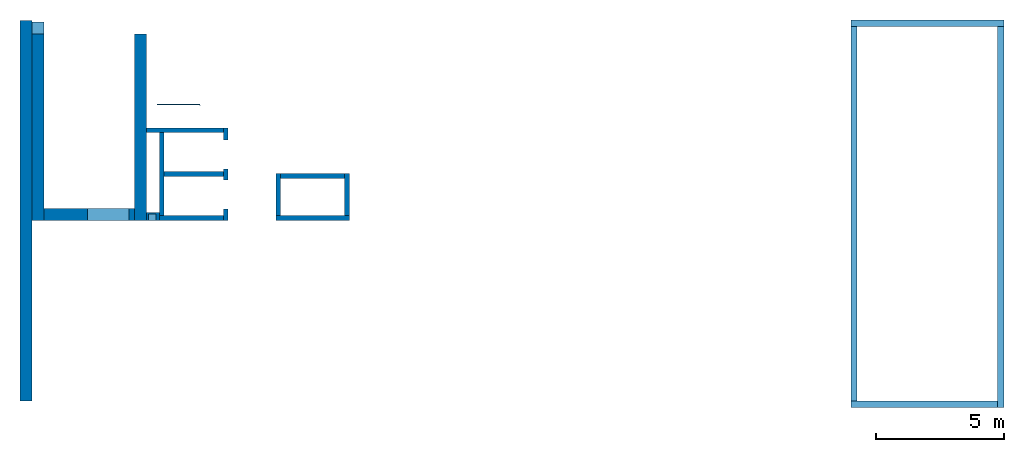
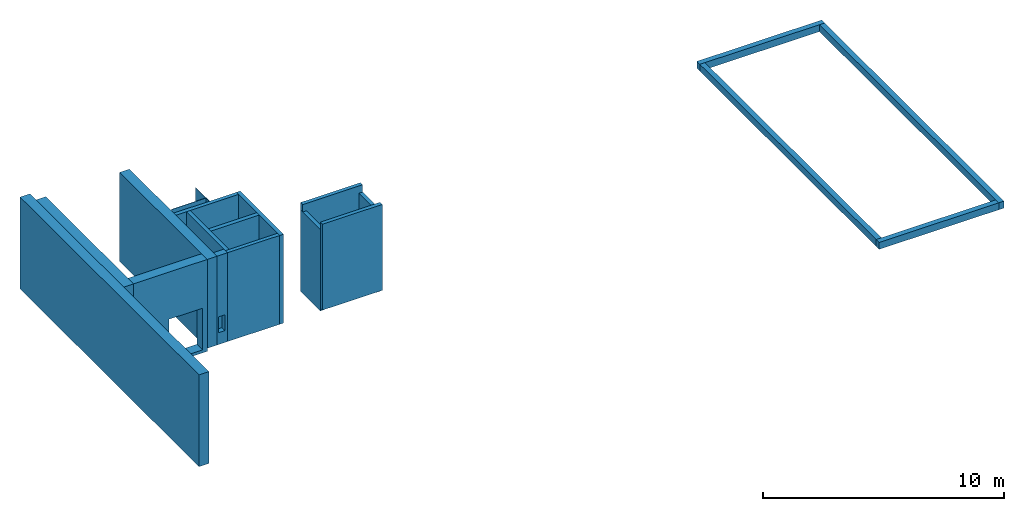
# One storey: 20 walls, 6 openings.
"""IFC4 building model written with IfcOpenShell, lengths in metres."""

from ifc_helpers import new_model, entity, si_unit, converted_unit, derived_unit, direction, frame, origin_with_axes, place, context, subcontext, project, spatial, polygons, material, type_object, element, save


model = new_model("IFC4")

# Units and contexts
model_context = context("Model", 3, precision=1e-05, world=origin_with_axes(), true_north=direction((0.0, 1.0)))
body_context = subcontext(model_context, "Body", "Model", "MODEL_VIEW")
ifc_project = project(units=[si_unit("LENGTHUNIT", "METRE"), si_unit("AREAUNIT", "SQUARE_METRE"), si_unit("VOLUMEUNIT", "CUBIC_METRE"), converted_unit("PLANEANGLEUNIT", "DEGREE", entity("IfcPlaneAngleMeasure", 0.0174532925199433), si_unit("PLANEANGLEUNIT", "RADIAN"), dimensions=[0, 0, 0, 0, 0, 0, 0]), converted_unit("TIMEUNIT", "Year", entity("IfcTimeMeasure", 31557600.0), si_unit("TIMEUNIT", "SECOND"), dimensions=[0, 0, 1, 0, 0, 0, 0]), si_unit("MASSUNIT", "GRAM", prefix="KILO"), si_unit("THERMODYNAMICTEMPERATUREUNIT", "DEGREE_CELSIUS"), si_unit("LUMINOUSINTENSITYUNIT", "LUMEN"), si_unit("ENERGYUNIT", "JOULE", prefix="MEGA"), derived_unit("THERMALCONDUCTANCEUNIT", [(si_unit("POWERUNIT", "WATT"), 1), (si_unit("LENGTHUNIT", "METRE"), -1), (si_unit("THERMODYNAMICTEMPERATUREUNIT", "KELVIN"), -1)]), derived_unit("SPECIFICHEATCAPACITYUNIT", [(si_unit("ENERGYUNIT", "JOULE"), 1), (si_unit("MASSUNIT", "GRAM", prefix="KILO"), -1), (si_unit("THERMODYNAMICTEMPERATUREUNIT", "KELVIN"), -1)]), derived_unit("MASSDENSITYUNIT", [(si_unit("MASSUNIT", "GRAM", prefix="KILO"), 1), (si_unit("VOLUMEUNIT", "CUBIC_METRE"), -1)])], contexts=[model_context])

# Site, building, storey
site_placement = place(None, origin_with_axes())
site = spatial("IfcSite", under=ifc_project, at=site_placement, CompositionType="ELEMENT")
building_placement = place(None, origin_with_axes())
building = spatial("IfcBuilding", under=site, at=building_placement, CompositionType="ELEMENT")
storey_placement = place(None, origin_with_axes())
storey = spatial("IfcBuildingStorey", under=building, at=storey_placement, Name="EG", CompositionType="ELEMENT", Elevation=0.0)

# Walls
ifc_material_1 = material(Name="Stahlbeton")
wall_type_1 = type_object("IfcWallType", Name="Stahlbeton 180", PredefinedType="NOTDEFINED")
wall_1_placement = place(None, frame((28.958, 7.05499994546755, 0.0), z_axis=(0.0, 0.0, 1.0), x_axis=(1.0, 0.0, 0.0)))
element("IfcWall", 1, at=wall_1_placement, inside=storey, type_object=wall_type_1, material=ifc_material_1, Name="Wand-001", PredefinedType="NOTDEFINED", context=body_context, shape_type="Tessellation", body=[
    polygons([(2.5, 0.180000000000001, 0.0), (2.5, 0.0, 0.0), (0.0, 0.0, 0.0), (0.0, 0.18, 0.0), (2.5, 0.180000000000001, 4.5), (2.5, 0.0, 4.5), (0.0, 0.0, 4.5), (0.0, 0.180000000000001, 4.5)], [[[1, 2, 3, 4]], [[2, 1, 5, 6]], [[2, 6, 7, 3]], [[8, 4, 3, 7]], [[5, 1, 4, 8]], [[6, 5, 8, 7]]], closed=True),
])
wall_2_placement = place(None, frame((29.138, 7.05499994546755, 0.0), z_axis=(0.0, 0.0, 1.0), x_axis=(0.0, 1.0, 0.0)))
element("IfcWall", 2, at=wall_2_placement, inside=storey, type_object=wall_type_1, material=ifc_material_1, Name="Wand-003", PredefinedType="NOTDEFINED", context=body_context, shape_type="Tessellation", body=[
    polygons([(3.42, 0.18, 4.5), (0.180000000000001, 0.18, 4.5), (0.180000000000001, 0.0, 4.5), (3.42, 0.0, 4.5), (3.42, 0.18, 0.0), (0.18, 0.18, 0.0), (0.18, 0.0, 0.0), (3.42, 0.0, 0.0)], [[[1, 2, 3, 4]], [[5, 6, 2, 1]], [[6, 7, 3, 2]], [[4, 3, 7, 8]], [[5, 1, 4, 8]], [[8, 7, 6, 5]]], closed=True),
])
wall_3_placement = place(None, frame((36.373, 7.05499994546756, -0.15), z_axis=(0.0, 0.0, 1.0), x_axis=(0.0, 1.0, 0.0)))
element("IfcWall", 3, at=wall_3_placement, inside=storey, type_object=wall_type_1, material=ifc_material_1, Name="Wand-001", PredefinedType="NOTDEFINED", context=body_context, shape_type="Tessellation", body=[
    polygons([(0.18, 0.18, 4.13), (0.179999999999998, 0.18, 0.0), (0.179999999999998, 0.0, 0.0), (0.18, 0.0, 4.13), (1.818, 0.18, 0.0), (1.818, 0.18, 4.13), (1.818, 0.0, 0.0), (1.818, 0.0, 4.13)], [[[1, 2, 3, 4]], [[5, 2, 1, 6]], [[7, 3, 2, 5]], [[4, 3, 7, 8]], [[6, 1, 4, 8]], [[6, 8, 7, 5]]], closed=True),
])
wall_4_placement = place(None, frame((31.638, 10.6549999454676, 0.0), z_axis=(0.0, 0.0, 1.0), x_axis=(-1.0, 0.0, 0.0)))
element("IfcWall", 4, at=wall_4_placement, inside=storey, type_object=wall_type_1, material=ifc_material_1, Name="Wand-003", PredefinedType="NOTDEFINED", context=body_context, shape_type="Tessellation", body=[
    polygons([(3.18, 0.18, 0.0), (3.18, 0.0, 0.0), (0.18, 0.0, 0.0), (0.18, 0.18, 0.0), (3.18, 0.18, 4.5), (3.18, 0.0, 4.5), (0.18, 0.0, 4.5), (0.18, 0.18, 4.5)], [[[1, 2, 3, 4]], [[2, 1, 5, 6]], [[2, 6, 7, 3]], [[8, 4, 3, 7]], [[5, 1, 4, 8]], [[6, 5, 8, 7]]], closed=True),
])

# Wall, openings
wall_5_placement = place(None, frame((31.638, 7.05499994546755, 0.0), z_axis=(0.0, 0.0, 1.0), x_axis=(0.0, 1.0, 0.0)))
wall_5 = element("IfcWall", 5, at=wall_5_placement, inside=storey, type_object=wall_type_1, material=ifc_material_1, Name="Wand-002", PredefinedType="NOTDEFINED", context=body_context, shape_type="Tessellation", body=[
    polygons([(2.0, 0.0, 0.0), (2.0, 0.0, 2.25), (3.13, 0.0, 2.25), (3.13, 0.0, 0.0), (3.6, 0.0, 0.0), (3.6, 0.0, 4.5), (0.0, 0.0, 4.5), (0.0, 0.0, 0.0), (0.450000000000002, 0.0, 0.0), (0.450000000000002, 0.0, 2.25), (1.58, 0.0, 2.25), (1.58, 0.0, 0.0), (2.0, 0.179999999999996, 0.0), (2.0, 0.179999999999996, 2.25), (3.13, 0.179999999999996, 2.25), (3.13, 0.179999999999996, 0.0), (3.6, 0.179999999999996, 0.0), (3.6, 0.179999999999996, 4.5), (0.0, 0.18, 4.5), (0.0, 0.18, 0.0), (0.450000000000002, 0.18, 0.0), (0.450000000000002, 0.18, 2.25), (1.58, 0.18, 2.25), (1.58, 0.18, 0.0)], [[[1, 2, 3, 4, 5, 6, 7, 8, 9, 10, 11, 12]], [[2, 1, 13, 14]], [[3, 2, 14, 15]], [[4, 3, 15, 16]], [[4, 16, 17, 5]], [[5, 17, 18, 6]], [[7, 6, 18, 19]], [[7, 19, 20, 8]], [[9, 8, 20, 21]], [[9, 21, 22, 10]], [[10, 22, 23, 11]], [[11, 23, 24, 12]], [[13, 1, 12, 24]], [[14, 13, 24, 23, 22, 21, 20, 19, 18, 17, 16, 15]]], closed=True),
])
opening_1_placement = place(wall_5_placement, frame((2.565, 0.0, 0.0), z_axis=(0.0, 0.0, 1.0), x_axis=(1.0, 0.0, 0.0)))
element("IfcOpeningElement", 6, at=opening_1_placement, cuts=wall_5, context=body_context, identifier="Reference", shape_type="Tessellation", body=[
    polygons([(-0.565, -0.00100000000000478, 2.25), (-0.565, -0.00100000000000478, 0.0), (0.565, -0.00100000000000478, 0.0), (0.565, -0.00100000000000478, 2.25), (-0.564999999999998, 0.181000000000001, 2.25), (-0.564999999999998, 0.181000000000001, 0.0), (0.565000000000001, 0.181000000000001, 0.0), (0.565000000000001, 0.181000000000001, 2.25)], [[[1, 2, 3, 4]], [[5, 6, 2, 1]], [[6, 7, 3, 2]], [[7, 8, 4, 3]], [[8, 5, 1, 4]], [[7, 6, 5, 8]]], closed=True),
])
opening_2_placement = place(wall_5_placement, frame((1.015, 0.0, 0.0), z_axis=(0.0, 0.0, 1.0), x_axis=(1.0, 0.0, 0.0)))
element("IfcOpeningElement", 7, at=opening_2_placement, cuts=wall_5, context=body_context, identifier="Reference", shape_type="Tessellation", body=[
    polygons([(-0.565, -0.00100000000000122, 2.25), (-0.565, -0.00100000000000122, 0.0), (0.565, -0.00100000000000122, 0.0), (0.565, -0.00100000000000122, 2.25), (-0.565, 0.181000000000004, 2.25), (-0.565, 0.181000000000004, 0.0), (0.565000000000001, 0.181000000000004, 0.0), (0.565000000000001, 0.181000000000004, 2.25)], [[[1, 2, 3, 4]], [[5, 6, 2, 1]], [[6, 7, 3, 2]], [[7, 8, 4, 3]], [[8, 5, 1, 4]], [[7, 6, 5, 8]]], closed=True),
])

# Walls
wall_6_placement = place(None, frame((36.373, 8.87299994546756, -0.15), z_axis=(0.0, 0.0, 1.0), x_axis=(-1.0, 0.0, 0.0)))
element("IfcWall", 8, at=wall_6_placement, inside=storey, type_object=wall_type_1, material=ifc_material_1, Name="Wand-001", PredefinedType="NOTDEFINED", context=body_context, shape_type="Tessellation", body=[
    polygons([(0.0, 0.18, 4.5), (0.0, 0.18, 4.13), (0.0, 0.0, 4.13), (0.0, 0.0, 4.5), (0.18, 0.18, 0.0), (0.18, 0.18, 4.13), (2.868, 0.18, 4.5), (2.868, 0.18, 4.13), (2.688, 0.18, 4.13), (2.688, 0.18, 0.0), (0.18, 0.0, 4.13), (0.18, 0.0, 0.0), (2.688, 0.0, 0.0), (2.688, 0.0, 4.13), (2.868, 0.0, 4.13), (2.868, 0.0, 4.5)], [[[1, 2, 3, 4]], [[5, 6, 2, 1, 7, 8, 9, 10]], [[6, 11, 3, 2]], [[3, 11, 12, 13, 14, 15, 16, 4]], [[1, 4, 16, 7]], [[5, 12, 11, 6]], [[16, 15, 8, 7]], [[8, 15, 14, 9]], [[9, 14, 13, 10]], [[13, 12, 5, 10]]], closed=True),
])
wall_7_placement = place(None, frame((33.505, 7.05499994546756, -0.15), z_axis=(0.0, 0.0, 1.0), x_axis=(0.0, 1.0, 0.0)))
element("IfcWall", 9, at=wall_7_placement, inside=storey, type_object=wall_type_1, material=ifc_material_1, Name="Wand-001", PredefinedType="NOTDEFINED", context=body_context, shape_type="Tessellation", body=[
    polygons([(0.18, 0.0, 4.13), (0.179999999999998, 0.0, 0.0), (0.179999999999998, -0.18, 0.0), (0.18, -0.18, 4.13), (1.818, 0.0, 0.0), (1.818, 0.0, 4.13), (1.818, -0.18, 0.0), (1.818, -0.18, 4.13)], [[[1, 2, 3, 4]], [[5, 2, 1, 6]], [[7, 3, 2, 5]], [[4, 3, 7, 8]], [[6, 1, 4, 8]], [[6, 8, 7, 5]]], closed=True),
])

# Space
space_placement = place(None, frame((28.883, 12.4404999136732, 0.0), z_axis=(0.0, 0.0, 1.0), x_axis=(0.0, -1.0, 0.0)))
space = spatial("IfcSpace", under=storey, at=space_placement, CompositionType="ELEMENT", PredefinedType="NOTDEFINED")

# Wall
ifc_material_2 = material(Name="Kunststoff")
wall_type_2 = type_object("IfcWallType", Name="Kunststoff 20", PredefinedType="NOTDEFINED")
wall_8_placement = place(None, frame((30.553, 11.5727499295704, -0.15), z_axis=(0.0, 0.0, 1.0), x_axis=(-1.0, 0.0, 0.0)))
element("IfcWall", 10, at=wall_8_placement, inside=space, type_object=wall_type_2, material=ifc_material_2, Name="Wand-003", PredefinedType="NOTDEFINED", context=body_context, shape_type="Tessellation", body=[
    polygons([(0.0199999999999996, -0.00999999999999979, 2.87), (0.0199999999999996, 0.00999999999999979, 2.87), (0.0199999999999996, 0.00999999999999979, 0.15), (0.0199999999999996, -0.00999999999999979, 0.15), (1.67, -0.00999999999999979, 2.87), (1.67, 0.00999999999999979, 2.87), (1.67, 0.00999999999999979, 0.15), (1.67, -0.00999999999999979, 0.15)], [[[1, 2, 3, 4]], [[5, 6, 2, 1]], [[2, 6, 7, 3]], [[3, 7, 8, 4]], [[5, 1, 4, 8]], [[6, 5, 8, 7]]], closed=True),
    polygons([(0.0199999999999996, 0.00999999999999979, 4.13), (0.0199999999999996, 0.00999999999999979, 2.9), (0.0199999999999996, -0.00999999999999979, 2.9), (0.0199999999999996, -0.00999999999999979, 4.13), (1.67, 0.00999999999999979, 4.13), (1.67, 0.00999999999999979, 2.9), (1.67, -0.00999999999999979, 2.9), (1.67, -0.00999999999999979, 4.13)], [[[1, 2, 3, 4]], [[5, 6, 2, 1]], [[6, 7, 3, 2]], [[4, 3, 7, 8]], [[4, 8, 5, 1]], [[8, 7, 6, 5]]], closed=True),
])

# Wall, openings
wall_9_placement = place(None, frame((30.553, 10.6549999454676, -0.15), z_axis=(0.0, 0.0, 1.0), x_axis=(0.0, 1.0, 0.0)))
wall_9 = element("IfcWall", 11, at=wall_9_placement, inside=space, type_object=wall_type_2, material=ifc_material_2, Name="Wand-003", PredefinedType="NOTDEFINED", context=body_context, shape_type="Tessellation", body=[
    polygons([(0.895499968205613, 0.0, 0.15), (0.895499968205613, 0.0, 2.245), (1.78549996820561, 0.0, 2.245), (1.78549996820561, 0.0, 2.87), (0.0, 0.0, 2.87), (0.0, 0.0, 2.245), (0.890000000000001, 0.0, 2.245), (0.890000000000001, 0.0, 0.15), (0.895499968205613, 0.0199999999999996, 0.15), (0.895499968205613, 0.0199999999999996, 2.245), (1.78549996820561, 0.0199999999999996, 2.245), (1.78549996820561, 0.0199999999999996, 2.87), (0.0, 0.0199999999999996, 2.87), (0.0, 0.0199999999999996, 2.245), (0.890000000000001, 0.0199999999999996, 2.245), (0.890000000000001, 0.0199999999999996, 0.15)], [[[1, 2, 3, 4, 5, 6, 7, 8]], [[2, 1, 9, 10]], [[11, 3, 2, 10]], [[3, 11, 12, 4]], [[4, 12, 13, 5]], [[6, 5, 13, 14]], [[6, 14, 15, 7]], [[7, 15, 16, 8]], [[9, 1, 8, 16]], [[10, 9, 16, 15, 14, 13, 12, 11]]], closed=True),
    polygons([(0.0, 0.0, 4.13), (0.0, 0.0, 2.9), (1.78549996820561, 0.0, 2.9), (1.78549996820561, 0.0, 4.13), (0.0, 0.0199999999999996, 4.13), (0.0, 0.0199999999999996, 2.9), (1.78549996820561, 0.0199999999999996, 2.9), (1.78549996820561, 0.0199999999999996, 4.13)], [[[1, 2, 3, 4]], [[5, 6, 2, 1]], [[6, 7, 3, 2]], [[4, 3, 7, 8]], [[4, 8, 5, 1]], [[8, 7, 6, 5]]], closed=True),
])
opening_3_placement = place(wall_9_placement, frame((1.34049996820561, 0.0, 0.2), z_axis=(0.0, 0.0, 1.0), x_axis=(1.0, 0.0, 0.0)))
element("IfcOpeningElement", 12, at=opening_3_placement, cuts=wall_9, context=body_context, identifier="Reference", shape_type="Tessellation", body=[
    polygons([(0.445, 0.0210000000000008, 2.045), (0.445, 0.0210000000000008, -0.05), (-0.445, 0.0210000000000008, -0.05), (-0.445, 0.0210000000000008, 2.045), (0.445, -0.00100000000000122, 2.045), (0.445, -0.00100000000000122, -0.05), (-0.445, -0.00100000000000122, -0.05), (-0.445, -0.00100000000000122, 2.045)], [[[1, 2, 3, 4]], [[5, 6, 2, 1]], [[6, 7, 3, 2]], [[7, 8, 4, 3]], [[8, 5, 1, 4]], [[7, 6, 5, 8]]], closed=True),
])
opening_4_placement = place(wall_9_placement, frame((0.445, 0.0, 0.2), z_axis=(0.0, 0.0, 1.0), x_axis=(1.0, 0.0, 0.0)))
element("IfcOpeningElement", 13, at=opening_4_placement, cuts=wall_9, context=body_context, identifier="Reference", shape_type="Tessellation", body=[
    polygons([(0.445, 0.0210000000000008, 2.045), (0.445, 0.0210000000000008, -0.05), (-0.445, 0.0210000000000008, -0.05), (-0.445, 0.0210000000000008, 2.045), (0.445, -0.00100000000000122, 2.045), (0.445, -0.00100000000000122, -0.05), (-0.445, -0.00100000000000122, -0.05), (-0.445, -0.00100000000000122, 2.045)], [[[1, 2, 3, 4]], [[5, 6, 2, 1]], [[6, 7, 3, 2]], [[7, 8, 4, 3]], [[8, 5, 1, 4]], [[7, 6, 5, 8]]], closed=True),
])

# Wall, opening
wall_type_3 = type_object("IfcWallType", Name="Stahlbeton 470", PredefinedType="NOTDEFINED")
wall_10_placement = place(None, frame((24.458, 7.52499994546755, -0.15), z_axis=(0.0, 0.0, 1.0), x_axis=(1.0, 0.0, 0.0)))
wall_10 = element("IfcWall", 14, at=wall_10_placement, inside=storey, type_object=wall_type_3, material=ifc_material_1, Name="Wand-001", PredefinedType="NOTDEFINED", context=body_context, shape_type="Tessellation", body=[
    polygons([(3.53, -0.470000000000001, 0.0), (3.53, -0.47, 4.65), (0.0, -0.47, 4.65), (0.0, -0.47, 0.0), (1.69000000000001, -0.47, 0.15), (1.69000000000001, -0.47, 2.26), (3.31, -0.47, 2.26), (3.31, -0.47, 0.15), (3.53, 0.0, 0.0), (3.53, 0.0, 4.65), (0.0, 0.0, 4.65), (0.0, 0.0, 0.0), (1.69000000000001, 0.0, 0.15), (1.69000000000001, 0.0, 2.26), (3.31, 0.0, 2.26), (3.31, 0.0, 0.15)], [[[1, 2, 3, 4], [5, 6, 7, 8]], [[1, 9, 10, 2]], [[2, 10, 11, 3]], [[11, 12, 4, 3]], [[9, 1, 4, 12]], [[13, 14, 6, 5]], [[14, 15, 7, 6]], [[15, 16, 8, 7]], [[16, 13, 5, 8]], [[9, 12, 11, 10], [13, 16, 15, 14]]], closed=True),
])
opening_5_placement = place(wall_10_placement, frame((2.5, 0.0, 0.15), z_axis=(0.0, 0.0, 1.0), x_axis=(1.0, 0.0, 0.0)))
element("IfcOpeningElement", 15, at=opening_5_placement, cuts=wall_10, context=body_context, identifier="Reference", shape_type="Tessellation", body=[
    polygons([(0.809999999999999, 0.00100000000000033, 2.11), (0.809999999999999, 0.00100000000000033, 0.0), (-0.809999999999999, 0.00100000000000033, 0.0), (-0.809999999999999, 0.00100000000000122, 2.11), (0.809999999999999, -0.471000000000001, 2.11), (0.809999999999999, -0.471000000000001, 0.0), (-0.809999999999999, -0.471000000000001, 0.0), (-0.809999999999999, -0.471, 2.11)], [[[1, 2, 3, 4]], [[5, 6, 2, 1]], [[6, 7, 3, 2]], [[7, 8, 4, 3]], [[8, 5, 1, 4]], [[7, 6, 5, 8]]], closed=True),
])

# Walls
wall_11_placement = place(None, frame((27.988, 14.3259998818788, 0.0), z_axis=(0.0, 0.0, 1.0), x_axis=(0.0, -1.0, 0.0)))
element("IfcWall", 16, at=wall_11_placement, inside=storey, type_object=wall_type_3, material=ifc_material_1, Name="Wand-001", PredefinedType="NOTDEFINED", context=body_context, shape_type="Tessellation", body=[
    polygons([(7.27099993641123, 0.469999999999999, 0.0), (7.27099993641123, 0.0, 0.0), (0.0, 0.0, 0.0), (0.0, 0.469999999999999, 0.0), (7.27099993641123, 0.469999999999999, 4.5), (7.27099993641123, 0.0, 4.5), (0.0, 0.0, 4.5), (0.0, 0.469999999999999, 4.5)], [[[1, 2, 3, 4]], [[2, 1, 5, 6]], [[2, 6, 7, 3]], [[8, 4, 3, 7]], [[5, 1, 4, 8]], [[6, 5, 8, 7]]], closed=True),
])
wall_12_placement = place(None, frame((24.458, 14.3318657372406, -0.15), z_axis=(0.0, 0.0, 1.0), x_axis=(0.0, -1.0, 0.0)))
element("IfcWall", 17, at=wall_12_placement, inside=storey, type_object=wall_type_3, material=ifc_material_1, Name="Wand-001", PredefinedType="NOTDEFINED", context=body_context, shape_type="Tessellation", body=[
    polygons([(-0.470000000000002, -0.469999999999999, 0.0), (-0.470000000000002, -0.469999999999999, 0.15), (-0.470000000000002, 0.0, 0.15), (-0.470000000000002, 0.0, 0.0), (0.0, -0.469999999999999, 4.65), (0.0, -0.469999999999999, 0.15), (7.27686579177299, -0.470000000000002, 0.0), (7.27686579177299, -0.470000000000002, 4.65), (0.0, 0.0, 0.15), (0.0, 0.0, 4.65), (7.27686579177299, 0.0, 4.65), (7.27686579177299, 0.0, 0.0)], [[[1, 2, 3, 4]], [[5, 6, 2, 1, 7, 8]], [[6, 9, 3, 2]], [[3, 9, 10, 11, 12, 4]], [[7, 1, 4, 12]], [[6, 5, 10, 9]], [[12, 11, 8, 7]], [[11, 10, 5, 8]]], closed=True),
])
wall_13_placement = place(None, frame((23.988, 14.8459998818788, -0.15), z_axis=(0.0, 0.0, 1.0), x_axis=(0.0, -1.0, 0.0)))
element("IfcWall", 18, at=wall_13_placement, inside=storey, type_object=wall_type_3, material=ifc_material_1, Name="Wand-001", PredefinedType="NOTDEFINED", context=body_context, shape_type="Tessellation", body=[
    polygons([(0.0, 0.0, 0.0), (0.0, 0.0, 4.65), (14.8459998818788, 0.0, 4.65), (14.8459998818788, 0.0, 0.0), (0.362999990943669, 0.0, 4.5), (0.362999990943669, 0.0, 4.13), (7.79099993641123, 0.0, 4.13), (14.4829998818788, 0.0, 4.13), (14.4829998818788, 0.0, 4.5), (7.79099993641123, 0.0, 4.5), (0.0, -0.469999999999999, 0.0), (0.0, -0.469999999999999, 4.65), (14.8459998818788, -0.469999999999999, 4.65), (14.8459998818788, -0.469999999999999, 0.0), (0.362999990943669, -0.100000000000008, 4.13), (0.362999990943669, -0.100000000000008, 4.5), (14.4829998818788, -0.100000000000005, 4.13), (14.4829998818788, -0.100000000000005, 4.5)], [[[1, 2, 3, 4], [5, 6, 7, 8, 9, 10]], [[1, 11, 12, 2]], [[2, 12, 13, 3]], [[4, 3, 13, 14]], [[11, 1, 4, 14]], [[15, 6, 5, 16]], [[8, 7, 6, 15, 17]], [[18, 9, 8, 17]], [[18, 16, 5, 10, 9]], [[12, 11, 14, 13]], [[17, 15, 16, 18]]], closed=True),
])

# Wall, opening
wall_type_4 = type_object("IfcWallType", Name="Stahlbeton 300", PredefinedType="NOTDEFINED")
wall_14_placement = place(None, frame((28.458, 7.05499994546755, 0.0), z_axis=(0.0, 0.0, 1.0), x_axis=(1.0, 0.0, 0.0)))
wall_14 = element("IfcWall", 19, at=wall_14_placement, inside=storey, type_object=wall_type_4, material=ifc_material_1, Name="Wand-001", PredefinedType="NOTDEFINED", context=body_context, shape_type="Tessellation", body=[
    polygons([(0.0, 0.0, 4.5), (0.0, 0.0, 0.0), (0.5, 0.0, 0.0), (0.5, 0.0, 4.5), (0.375425898351669, 0.0, 0.6), (0.0754258983516713, 0.0, 0.6), (0.0754258983516713, 0.0, 1.4), (0.375425898351669, 0.0, 1.4), (0.0, 0.3, 4.5), (0.0, 0.3, 0.0), (0.5, 0.3, 0.0), (0.5, 0.300000000000001, 4.5), (0.0754258983516713, 0.25, 0.6), (0.375425898351669, 0.25, 0.6), (0.0754258983516713, 0.25, 1.4), (0.375425898351669, 0.25, 1.4)], [[[1, 2, 3, 4], [5, 6, 7, 8]], [[1, 9, 10, 2]], [[2, 10, 11, 3]], [[4, 3, 11, 12]], [[9, 1, 4, 12]], [[13, 6, 5, 14]], [[15, 7, 6, 13]], [[16, 8, 7, 15]], [[14, 5, 8, 16]], [[10, 9, 12, 11]], [[13, 14, 16, 15]]], closed=True),
])
opening_6_placement = place(wall_14_placement, frame((-28.458, -7.05499994546755, 0.0), z_axis=(0.0, 0.0, 1.0), x_axis=(1.0, 0.0, 0.0)))
element("IfcOpeningElement", 20, at=opening_6_placement, cuts=wall_14, PredefinedType="NOTDEFINED", context=body_context, identifier="Reference", shape_type="Tessellation", body=[
    polygons([(28.5334258983517, 7.30499994546755, 0.6), (28.8334258983517, 7.30499994546755, 0.6), (28.8334258983517, 6.75499994546755, 0.6), (28.5334258983517, 6.75499994546755, 0.6), (28.5334258983517, 7.30499994546755, 1.4), (28.8334258983517, 7.30499994546755, 1.4), (28.8334258983517, 6.75499994546755, 1.4), (28.5334258983517, 6.75499994546755, 1.4)], [[[1, 2, 3, 4]], [[1, 5, 6, 2]], [[2, 6, 7, 3]], [[4, 3, 7, 8]], [[5, 1, 4, 8]], [[6, 5, 8, 7]]], closed=True),
])

# Walls
wall_type_5 = type_object("IfcWallType", Name="Stahlbeton 250", PredefinedType="NOTDEFINED")
wall_15_placement = place(None, frame((61.676, 0.0, -0.35), z_axis=(0.0, 0.0, 1.0), x_axis=(-1.0, 0.0, 0.0)))
element("IfcWall", 21, at=wall_15_placement, inside=storey, type_object=wall_type_5, material=ifc_material_1, Name="Wand-005", PredefinedType="NOTDEFINED", context=body_context, shape_type="Tessellation", body=[
    polygons([(5.73, 0.25, 0.0), (5.73, 0.0, 0.0), (0.0, 0.0, 0.0), (0.0, 0.25, 0.0), (5.73, 0.25, 0.35), (5.73, 0.0, 0.35), (0.0, 0.0, 0.35), (0.0, 0.25, 0.35)], [[[1, 2, 3, 4]], [[2, 1, 5, 6]], [[2, 6, 7, 3]], [[8, 4, 3, 7]], [[5, 1, 4, 8]], [[6, 5, 8, 7]]], closed=True),
])
wall_16_placement = place(None, frame((61.676, 14.6229999454676, -0.35), z_axis=(0.0, 0.0, 1.0), x_axis=(0.0, -1.0, 0.0)))
element("IfcWall", 22, at=wall_16_placement, inside=storey, type_object=wall_type_5, material=ifc_material_1, Name="Wand-003", PredefinedType="NOTDEFINED", context=body_context, shape_type="Tessellation", body=[
    polygons([(14.8729999454676, 0.25, 0.0), (14.8729999454676, 0.0, 0.0), (0.0, 0.0, 0.0), (0.0, 0.25, 0.0), (14.8729999454676, 0.25, 0.35), (14.8729999454676, 0.0, 0.35), (0.0, 0.0, 0.35), (0.0, 0.25, 0.35)], [[[1, 2, 3, 4]], [[2, 1, 5, 6]], [[2, 6, 7, 3]], [[8, 4, 3, 7]], [[5, 1, 4, 8]], [[6, 5, 8, 7]]], closed=True),
])
wall_17_placement = place(None, frame((56.196, 14.6229999454676, -0.35), z_axis=(0.0, 0.0, 1.0), x_axis=(1.0, 0.0, 0.0)))
element("IfcWall", 23, at=wall_17_placement, inside=storey, type_object=wall_type_5, material=ifc_material_1, Name="Wand-002", PredefinedType="NOTDEFINED", context=body_context, shape_type="Tessellation", body=[
    polygons([(5.73, 0.25, 0.0), (5.73, 0.0, 0.0), (-0.25, 0.0, 0.0), (-0.25, 0.25, 0.0), (5.73, 0.25, 0.35), (5.73, 0.0, 0.35), (-0.25, 0.0, 0.35), (-0.25, 0.25, 0.35)], [[[1, 2, 3, 4]], [[2, 1, 5, 6]], [[2, 6, 7, 3]], [[8, 4, 3, 7]], [[5, 1, 4, 8]], [[6, 5, 8, 7]]], closed=True),
])
wall_18_placement = place(None, frame((56.196, 0.0, -0.35), z_axis=(0.0, 0.0, 1.0), x_axis=(0.0, 1.0, 0.0)))
element("IfcWall", 24, at=wall_18_placement, inside=storey, type_object=wall_type_5, material=ifc_material_1, Name="Wand-005", PredefinedType="NOTDEFINED", context=body_context, shape_type="Tessellation", body=[
    polygons([(14.6229999454676, 0.25, 0.0), (14.6229999454676, 0.0, 0.0), (0.0, 0.0, 0.0), (0.0, 0.25, 0.0), (14.6229999454676, 0.25, 0.35), (14.6229999454676, 0.0, 0.35), (0.0, 0.0, 0.35), (0.0, 0.25, 0.35)], [[[1, 2, 3, 4]], [[2, 1, 5, 6]], [[2, 6, 7, 3]], [[8, 4, 3, 7]], [[5, 1, 4, 8]], [[6, 5, 8, 7]]], closed=True),
])
wall_type_6 = type_object("IfcWallType", Name="Stahlbeton 200", PredefinedType="NOTDEFINED")
wall_19_placement = place(None, frame((29.138, 8.85499994546755, 0.0), z_axis=(0.0, 0.0, 1.0), x_axis=(1.0, 0.0, 0.0)))
element("IfcWall", 25, at=wall_19_placement, inside=storey, type_object=wall_type_6, material=ifc_material_1, Name="Wand-001", PredefinedType="NOTDEFINED", context=body_context, shape_type="Tessellation", body=[
    polygons([(2.32, 0.0999999999999996, 0.0), (2.32, -0.0999999999999996, 0.0), (0.0, -0.0999999999999996, 0.0), (0.0, 0.0999999999999996, 0.0), (2.32, 0.0999999999999996, 4.5), (2.32, -0.0999999999999996, 4.5), (0.0, -0.0999999999999996, 4.5), (0.0, 0.0999999999999996, 4.5)], [[[1, 2, 3, 4]], [[2, 1, 5, 6]], [[2, 6, 7, 3]], [[8, 4, 3, 7]], [[5, 1, 4, 8]], [[6, 5, 8, 7]]], closed=True),
])
wall_type_7 = type_object("IfcWallType", Name="03a", PredefinedType="NOTDEFINED")
wall_20_placement = place(None, frame((33.505, 7.05499994546756, -0.15), z_axis=(0.0, 0.0, 1.0), x_axis=(1.0, 0.0, 0.0)))
element("IfcWall", 26, at=wall_20_placement, inside=storey, type_object=wall_type_7, material=ifc_material_1, Name="Wand-001", PredefinedType="NOTDEFINED", context=body_context, shape_type="Tessellation", body=[
    polygons([(2.868, 0.0, 4.13), (2.868, 0.0, 0.15), (2.868, 0.179999999999998, 0.15), (2.868, 0.18, 4.13), (0.0, 0.0, 4.13), (0.0, 0.0, 0.15), (2.868, 0.0, 4.5), (0.0, 0.0, 4.5), (0.0, 0.179999999999998, 0.15), (0.0, 0.18, 4.13), (0.0, 0.18, 4.5), (2.868, 0.18, 4.5)], [[[1, 2, 3, 4]], [[5, 6, 2, 1, 7, 8]], [[6, 9, 3, 2]], [[4, 3, 9, 10, 11, 12]], [[7, 1, 4, 12]], [[10, 9, 6, 5]], [[11, 8, 7, 12]], [[10, 5, 8, 11]]], closed=True),
])

save(model, "model.ifc")
